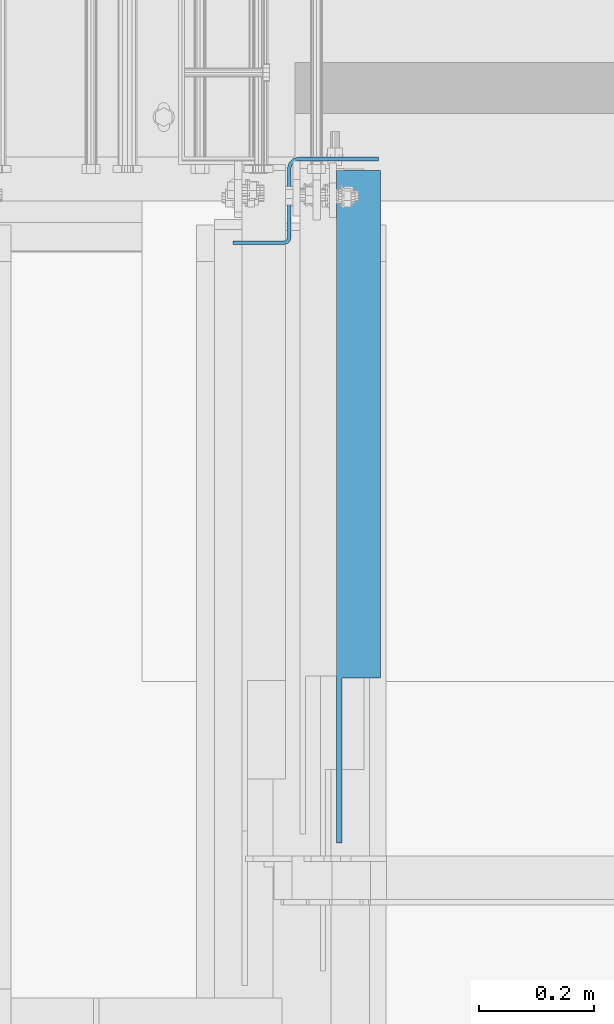
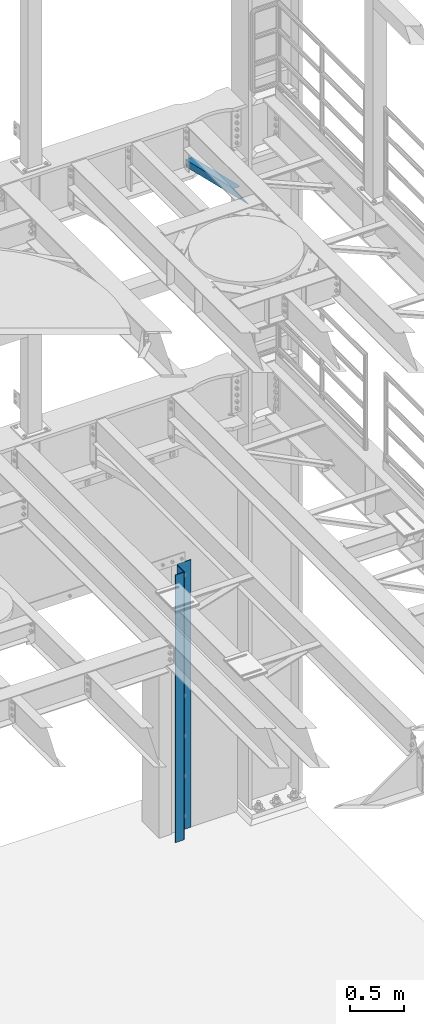
# One storey, part 1075 of 1876: 2 beams, 2 elements without a shape of their own.
"""IFC2X3 building model written with IfcOpenShell, lengths in millimetres."""

from ifc_helpers import new_model, si_unit, frame, origin_with_axes, place, context, subcontext, project, spatial, faceted_brep, material, type_object, element, aggregate, save


model = new_model("IFC2X3")

# Units and contexts
model_context = context("Model", 3, precision=1e-05, world=origin_with_axes())
body_context = subcontext(model_context, "Body", "Model", "MODEL_VIEW")
ifc_project = project(units=[si_unit("LENGTHUNIT", "METRE", prefix="MILLI"), si_unit("AREAUNIT", "SQUARE_METRE"), si_unit("VOLUMEUNIT", "CUBIC_METRE"), si_unit("MASSUNIT", "GRAM", prefix="KILO"), si_unit("TIMEUNIT", "SECOND"), si_unit("PLANEANGLEUNIT", "RADIAN"), si_unit("SOLIDANGLEUNIT", "STERADIAN"), si_unit("THERMODYNAMICTEMPERATUREUNIT", "DEGREE_CELSIUS"), si_unit("LUMINOUSINTENSITYUNIT", "LUMEN")], contexts=[model_context])

# Site, building, storey
site_placement = place(None, origin_with_axes())
site = spatial("IfcSite", under=ifc_project, at=site_placement, CompositionType="ELEMENT")
building_placement = place(site_placement, origin_with_axes())
building = spatial("IfcBuilding", under=site, at=building_placement, Name="Undefined", CompositionType="ELEMENT")
storey_placement = place(building_placement, origin_with_axes())
storey = spatial("IfcBuildingStorey", under=building, at=storey_placement, Name="Undefined", CompositionType="ELEMENT", Elevation=0.0)

# Assembly, beam
assembly_1_placement = place(storey_placement, origin_with_axes())
assembly_1 = element("IfcElementAssembly", 1, at=assembly_1_placement, inside=storey, AssemblyPlace="NOTDEFINED", PredefinedType="RIGID_FRAME")
ifc_material = material(Name="STEEL/A36")
beam_type_1 = type_object("IfcBeamType", Name="L3X3X3/8", PredefinedType="NOTDEFINED")
beam_1_placement = place(assembly_1_placement, frame((6765.925, 12840.0279763324, 7802.01022141264), z_axis=(1.0, 0.0, 0.0), x_axis=(0.0, 0.972828834357878, -0.231525504085172)))
beam_1 = element("IfcBeam", 2, at=beam_1_placement, type_object=beam_type_1, material=ifc_material, ObjectType="L3X3X3/8", context=body_context, shape_type="Brep", body=[
    faceted_brep([(0.0, 38.1000000000004, -38.1), (0.0, 38.1000000000004, 38.1), (867.661726641916, 38.1000000002095, 38.1000000000004), (867.661726641916, 38.1000000002095, -38.1000000000004), (-40.0223495126247, 28.5749999999825, 38.1000000000004), (867.584845052073, 28.5750000002117, 38.1000000000004), (-40.0223495126247, 28.5749999999825, -28.5749999999998), (867.584845052073, 28.5750000002117, -28.5749999999998), (-320.178796151862, -38.1000000000677, -28.5749999999998), (867.04667392318, -38.0999999997694, -28.5749999999998), (-320.178796151862, -38.1000000000677, -38.1000000000004), (867.04667392318, -38.0999999997694, -38.1000000000004)], [[[0, 1, 2, 3]], [[1, 4, 5, 2]], [[4, 6, 7, 5]], [[6, 8, 9, 7]], [[8, 10, 11, 9]], [[10, 0, 3, 11]], [[5, 7, 9, 11, 3, 2]], [[10, 8, 6, 4, 1, 0]]]),
])
aggregate(assembly_1, [beam_1])

assembly_2_placement = place(storey_placement, origin_with_axes())
assembly_2 = element("IfcElementAssembly", 3, at=assembly_2_placement, inside=storey, Name="BENT PLATE", AssemblyPlace="NOTDEFINED", PredefinedType="RIGID_FRAME")
beam_type_2 = type_object("IfcBeamType", PredefinedType="NOTDEFINED")
beam_2_placement = place(assembly_2_placement, frame((6800.8504444276, 13712.8250188271, 1524.0), z_axis=(0.0, 0.0, 1.0), x_axis=(-1.0, 0.0, 0.0)))
beam_2 = element("IfcBeam", 4, at=beam_2_placement, type_object=beam_type_2, material=ifc_material, Name="BENT PLATE", context=body_context, shape_type="Brep", body=[
    faceted_brep([(-9.88620740827173e-10, 3.17500000000291, -1524.0), (-9.88620740827173e-10, 3.17500000000291, 1524.0), (139.699995674332, 3.17500000233849, 1524.0), (139.699995674332, 3.17500000233849, -1524.0), (9.877112461254e-10, -3.17499999999563, 1524.0), (9.877112461254e-10, -3.17499999999563, -1524.0), (139.699995674433, -3.17499999766005, -1524.0), (139.699995674433, -3.17499999766005, 1524.0), (146.049995120877, 4.87647707938777, 1524.0), (146.049995120877, 4.87647707938777, -1524.0), (149.224994891681, -0.622784366971246, -1524.0), (149.224994891681, -0.622784366971246, 1524.0), (156.197778657744, 6.34999852737565, -1524.0), (156.197778657744, 6.34999852737565, 1524.0), (150.698517608314, 9.52499898568021, 1524.0), (150.698517608314, 9.52499898568021, -1524.0), (158.749995483897, 15.8749974256571, -1524.0), (158.749995483897, 15.8749974256571, 1524.0), (152.399995483897, 15.8749982194131, 1524.0), (152.399995483897, 15.8749982194131, -1524.0), (152.400010565148, 136.524999450914, 1524.0), (152.400010565149, 136.524999450914, -1524.0), (158.750010565149, 136.52499865716, -1524.0), (158.750010565149, 136.52499865716, 1524.0), (154.101488705283, 142.874999142863, 1524.0), (154.101488705283, 142.874999142863, -1524.0), (159.600749622438, 139.69999845545, -1524.0), (159.600749622438, 139.69999845545, 1524.0), (161.925011157189, 142.024259409132, -1524.0), (161.925011157189, 142.024259409132, 1524.0), (158.750011844597, 147.523521120042, 1524.0), (158.750011844597, 147.523521120042, -1524.0), (165.100011168164, 142.87499767267, -1524.0), (165.100011168164, 142.87499767267, 1524.0), (165.100011961914, 149.224997672669, 1524.0), (165.100011961914, 149.224997672669, -1524.0), (254.000018256122, 149.224986560088, 1524.0), (254.000018256122, 149.224986560088, -1524.0), (254.000017462372, 142.874986560088, 1524.0), (254.000017462372, 142.874986560088, -1524.0)], [[[0, 1, 2, 3]], [[4, 5, 6, 7]], [[5, 4, 1, 0]], [[3, 2, 8, 9]], [[7, 6, 10, 11]], [[10, 12, 13, 11]], [[8, 14, 15, 9]], [[12, 16, 17, 13]], [[14, 18, 19, 15]], [[19, 18, 20, 21]], [[17, 16, 22, 23]], [[21, 20, 24, 25]], [[23, 22, 26, 27]], [[26, 28, 29, 27]], [[24, 30, 31, 25]], [[28, 32, 33, 29]], [[30, 34, 35, 31]], [[35, 34, 36, 37]], [[34, 30, 24, 20, 18, 14, 8, 2, 1, 4, 7, 11, 13, 17, 23, 27, 29, 33, 38, 36]], [[33, 32, 39, 38]], [[32, 28, 26, 22, 16, 12, 10, 6, 5, 0, 3, 9, 15, 19, 21, 25, 31, 35, 37, 39]], [[38, 39, 37, 36]]]),
])
aggregate(assembly_2, [beam_2])

save(model, "model.ifc")
